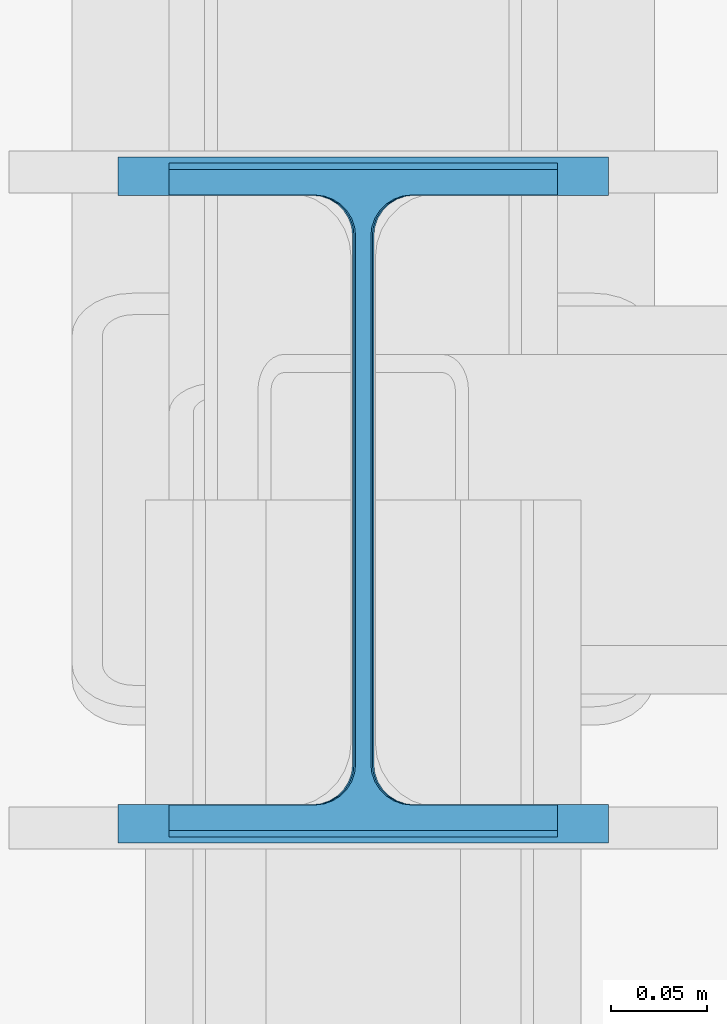
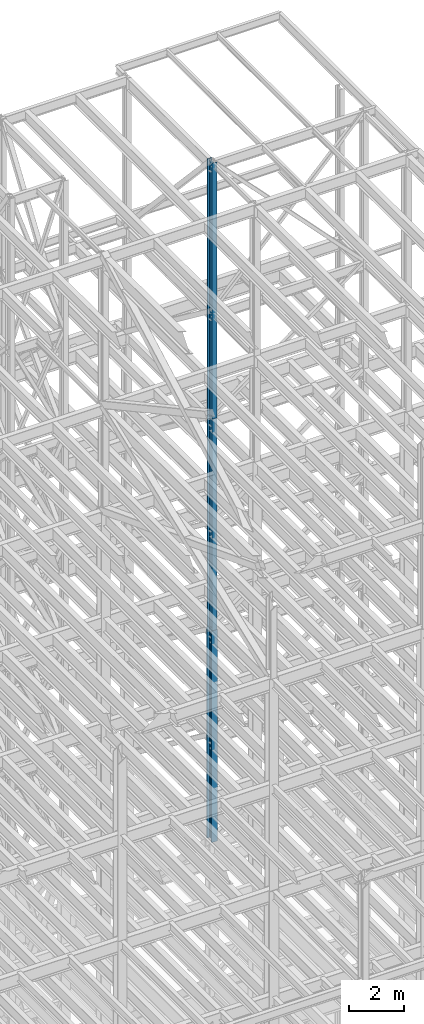
# One storey, part 114 of 150: 3 columns.
"""IFC2X3 building model written with IfcOpenShell, lengths in millimetres."""

from ifc_helpers import new_model, si_unit, frame, origin_with_axes, origin_2d_with_axis, place, context, subcontext, project, spatial, i_section, extrude, material, type_object, element, save


model = new_model("IFC2X3")

# Units and contexts
model_context = context("Model", 3, precision=1e-05, world=origin_with_axes())
body_context = subcontext(model_context, "Body", "Model", "MODEL_VIEW")
ifc_project = project(units=[si_unit("LENGTHUNIT", "METRE", prefix="MILLI"), si_unit("AREAUNIT", "SQUARE_METRE"), si_unit("VOLUMEUNIT", "CUBIC_METRE"), si_unit("MASSUNIT", "GRAM", prefix="KILO"), si_unit("TIMEUNIT", "SECOND"), si_unit("PLANEANGLEUNIT", "RADIAN"), si_unit("SOLIDANGLEUNIT", "STERADIAN"), si_unit("THERMODYNAMICTEMPERATUREUNIT", "DEGREE_CELSIUS"), si_unit("LUMINOUSINTENSITYUNIT", "LUMEN")], contexts=[model_context])

# Site, building, storey
site_placement = place(None, origin_with_axes())
site = spatial("IfcSite", under=ifc_project, at=site_placement, CompositionType="ELEMENT")
building_placement = place(site_placement, origin_with_axes())
building = spatial("IfcBuilding", under=site, at=building_placement, Name="Undefined", CompositionType="ELEMENT")
storey_placement = place(building_placement, origin_with_axes())
storey = spatial("IfcBuildingStorey", under=building, at=storey_placement, Name="Undefined", CompositionType="ELEMENT", Elevation=0.0)

# Columns
ifc_material = material(Name="STEEL/A992")
column_type_1 = type_object("IfcColumnType", Name="W14X43", PredefinedType="NOTDEFINED")
column_1_placement = place(storey_placement, frame((82194.4, 25628.6, 54483.0), z_axis=(0.0, 0.0, 1.0), x_axis=(1.0, 0.0, 0.0)))
element("IfcColumn", 1, at=column_1_placement, inside=storey, type_object=column_type_1, material=ifc_material, Name="COLUMN", ObjectType="W14X43", context=body_context, shape_type="SweptSolid", body=[
    extrude(i_section(OverallWidth=203.2, OverallDepth=346.075, WebThickness=7.9375, FlangeThickness=13.462, FilletRadius=21.4629, at=origin_2d_with_axis()), frame((0.0, 0.0, 11429.998857), z_axis=(0.0, 0.0, -1.0), x_axis=(-1.0, 0.0, 0.0)), (0.0, 0.0, 1.0), 11429.998857),
])
column_type_2 = type_object("IfcColumnType", Name="W14X53", PredefinedType="NOTDEFINED")
column_2_placement = place(storey_placement, frame((82194.4, 25628.6, 45034.2), z_axis=(0.0, 0.0, 1.0), x_axis=(1.0, 0.0, 0.0)))
element("IfcColumn", 2, at=column_2_placement, inside=storey, type_object=column_type_2, material=ifc_material, Name="COLUMN", ObjectType="W14X53", context=body_context, shape_type="SweptSolid", body=[
    extrude(i_section(OverallWidth=203.2, OverallDepth=352.425, WebThickness=9.5249, FlangeThickness=16.764, FilletRadius=21.336, at=origin_2d_with_axis()), frame((0.0, 0.0, 9448.8), z_axis=(0.0, 0.0, -1.0), x_axis=(-1.0, 0.0, 0.0)), (0.0, 0.0, 1.0), 9448.8),
])
column_type_3 = type_object("IfcColumnType", Name="W14X74", PredefinedType="NOTDEFINED")
column_3_placement = place(storey_placement, frame((82194.4, 25628.6, 35585.4), z_axis=(0.0, 0.0, 1.0), x_axis=(1.0, 0.0, 0.0)))
element("IfcColumn", 3, at=column_3_placement, inside=storey, type_object=column_type_3, material=ifc_material, Name="COLUMN", ObjectType="W14X74", context=body_context, shape_type="SweptSolid", body=[
    extrude(i_section(OverallWidth=256.54, OverallDepth=358.775, WebThickness=11.1125, FlangeThickness=19.939, FilletRadius=21.336, at=origin_2d_with_axis()), frame((0.0, 0.0, 9448.8), z_axis=(0.0, 0.0, -1.0), x_axis=(-1.0, 0.0, 0.0)), (0.0, 0.0, 1.0), 9448.8),
])

save(model, "model.ifc")
